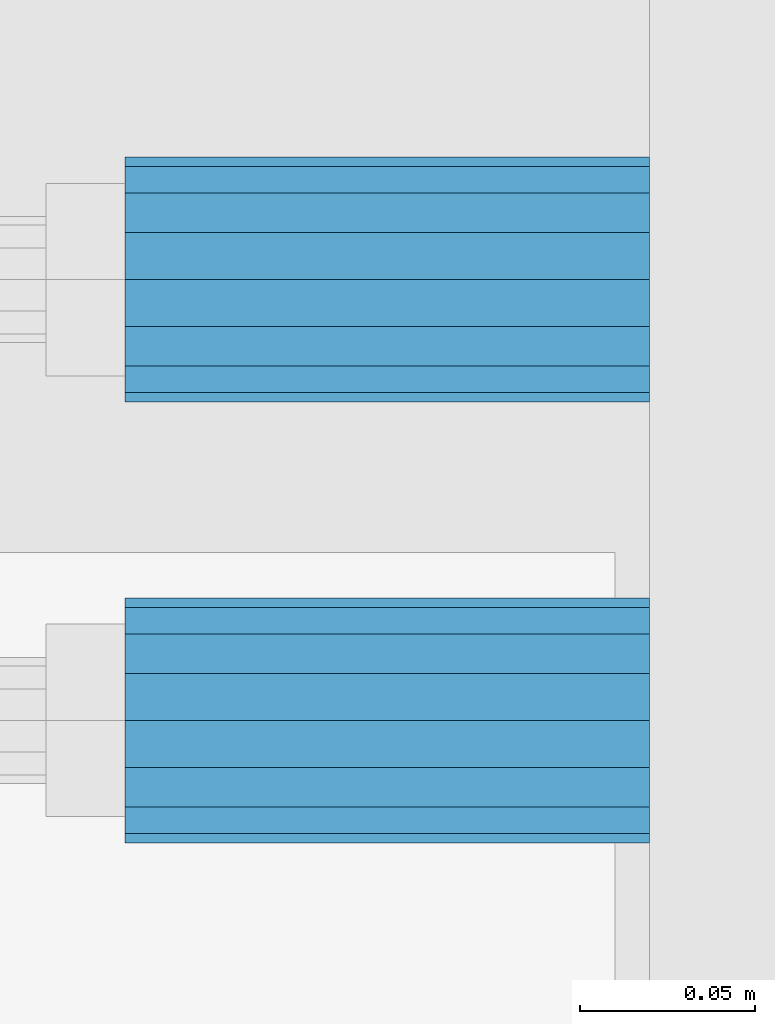
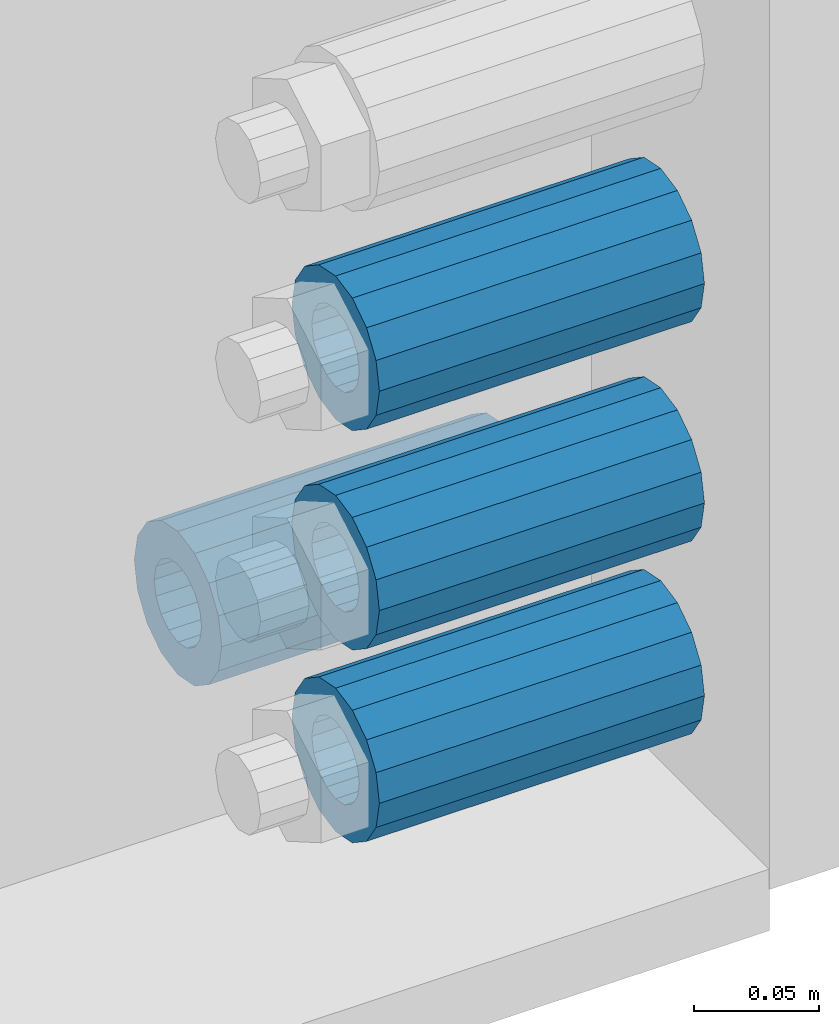
# One storey, part 168 of 240: 4 beams.
"""IFC2X3 building model written with IfcOpenShell, lengths in millimetres."""

import ifcopenshell
import ifcopenshell.guid

model = None  # the IFC model being written
_history = None  # IfcOwnerHistory: only IFC2X3 demands one
_inside = {}  # id of a spatial element -> (the spatial element, [elements in it])
_under = {}  # id of a project, library or spatial element -> (it, [spatial elements below it])
_declared = {}  # id of a project -> (the project, [libraries it declares])
_typed = {}  # id of a type object -> (the type object, [elements of that type])
_made_of = {}  # id of a material, layer set ... -> (it, [elements and type objects made of it])


def new_model(schema):
    """Start an empty IFC model of exactly this schema.

    Asked for "IFC4X3", IfcOpenShell would pick the latest addendum, in which some entities
    have other attributes; the version numbers below select the first issue.
    IFC2X3 requires an IfcOwnerHistory on every rooted entity: one is made here for all.
    """
    global model, _history
    if schema == "IFC4X3":
        model = ifcopenshell.file(schema_version=(4, 3, 0, 0))
    else:
        model = ifcopenshell.file(schema=schema)
    _inside.clear()
    _under.clear()
    _declared.clear()
    _typed.clear()
    _made_of.clear()
    _history = None
    if model.schema == "IFC2X3":
        org = make("IfcOrganization", Name="unknown")
        user = make(
            "IfcPersonAndOrganization",
            ThePerson=make("IfcPerson", FamilyName="unknown"),
            TheOrganization=org,
        )
        app = make(
            "IfcApplication",
            ApplicationDeveloper=org,
            Version="unknown",
            ApplicationFullName="unknown",
            ApplicationIdentifier="unknown",
        )
        _history = make(
            "IfcOwnerHistory",
            OwningUser=user,
            OwningApplication=app,
            ChangeAction="ADDED",
            CreationDate=0,
        )
    return model


def make(cls, **values):
    """One entity of the class cls with the attributes given. An attribute that is None is left unset."""
    return model.create_entity(
        cls, **{name: value for name, value in values.items() if value is not None}
    )


def rooted(cls, **values):
    """An entity with a GlobalId (a new one), such as an element, a storey or a relation."""
    return make(cls, GlobalId=ifcopenshell.guid.new(), OwnerHistory=_history, **values)


def si_unit(unit_type, name, prefix=None):
    """IfcSIUnit, for example si_unit("LENGTHUNIT", "METRE", prefix="MILLI")."""
    return make("IfcSIUnit", UnitType=unit_type, Prefix=prefix, Name=name)


def assignment(units):
    """IfcUnitAssignment: the units of a project."""
    return None if units is None else make("IfcUnitAssignment", Units=units)


def point(xyz):
    """IfcCartesianPoint."""
    return None if xyz is None else make("IfcCartesianPoint", Coordinates=xyz)


def direction(xyz):
    """IfcDirection."""
    return None if xyz is None else make("IfcDirection", DirectionRatios=xyz)


def frame(location, z_axis=None, x_axis=None):
    """IfcAxis2Placement3D, a coordinate frame: its origin and axes. An axis left out is left unset."""
    return make(
        "IfcAxis2Placement3D",
        Location=point(location),
        Axis=direction(z_axis),
        RefDirection=direction(x_axis),
    )


def origin_with_axes():
    """The frame at (0, 0, 0) with the z axis (0, 0, 1) and the x axis (1, 0, 0) written out."""
    return frame((0.0, 0.0, 0.0), z_axis=(0.0, 0.0, 1.0), x_axis=(1.0, 0.0, 0.0))


def place(relative_to, where):
    """IfcLocalPlacement: puts the frame where relative to a parent placement (None: the world)."""
    return make(
        "IfcLocalPlacement", PlacementRelTo=relative_to, RelativePlacement=where
    )


def context(
    kind, dimensions, precision=None, world=None, true_north=None, identifier=None
):
    """IfcGeometricRepresentationContext, for example the 3D "Model" context."""
    return make(
        "IfcGeometricRepresentationContext",
        ContextIdentifier=identifier,
        ContextType=kind,
        CoordinateSpaceDimension=dimensions,
        Precision=precision,
        WorldCoordinateSystem=world,
        TrueNorth=true_north,
    )


def subcontext(parent, identifier, kind, view, scale=None):
    """IfcGeometricRepresentationSubContext, for example "Body" below "Model"."""
    return make(
        "IfcGeometricRepresentationSubContext",
        ContextIdentifier=identifier,
        ContextType=kind,
        ParentContext=parent,
        TargetScale=scale,
        TargetView=view,
    )


def project(units=None, contexts=None):
    """IfcProject with its units and contexts."""
    return rooted(
        "IfcProject",
        Name="project",
        RepresentationContexts=contexts,
        UnitsInContext=assignment(units),
    )


def spatial(cls, under=None, at=None, **own):
    """A site, building, storey or space (cls), placed at a placement, below another one or the project."""
    s = rooted(cls, ObjectPlacement=at, **own)
    if under is not None:
        _under.setdefault(under.id(), (under, []))[1].append(s)
    return s


def faces_of(points, faces, orient=None, outer=None):
    """IfcFace entities. A face is a list of loops; a loop is a list of indices into points, from 0.

    orient and outer hold one flag for each loop. By default every Orientation is true, the
    first loop of a face is its IfcFaceOuterBound and the others are IfcFaceBound.
    """
    made = []
    for i, loops in enumerate(faces):
        bounds = []
        for j, loop in enumerate(loops):
            is_outer = j == 0 if outer is None else outer[i][j]
            bounds.append(
                make(
                    "IfcFaceOuterBound" if is_outer else "IfcFaceBound",
                    Bound=make("IfcPolyLoop", Polygon=[points[k] for k in loop]),
                    Orientation=True if orient is None else orient[i][j],
                )
            )
        made.append(make("IfcFace", Bounds=bounds))
    return made


def faceted_brep(points, faces, orient=None, outer=None, voids=None):
    """IfcFacetedBrep: a solid bounded by flat faces; with voids (closed shells), ...WithVoids."""
    shared = [point(p) for p in points]
    hull = make("IfcClosedShell", CfsFaces=faces_of(shared, faces, orient, outer))
    if voids is None:
        return make("IfcFacetedBrep", Outer=hull)
    return make(
        "IfcFacetedBrepWithVoids",
        Outer=hull,
        Voids=[
            make(cls, CfsFaces=faces_of(shared, fs, o, b)) for cls, fs, o, b in voids
        ],
    )


def shape(context_of_items, identifier, shape_type, items):
    """IfcShapeRepresentation: the items that make up one representation, for example the "Body"."""
    return make(
        "IfcShapeRepresentation",
        ContextOfItems=context_of_items,
        RepresentationIdentifier=identifier,
        RepresentationType=shape_type,
        Items=items,
    )


def material(Name=None, Category=None):
    """IfcMaterial."""
    return make("IfcMaterial", Name=Name, Category=Category)


def made_of(thing, what):
    """Note that an element or type object is made of a material, layer set ...; save() writes the relation."""
    if what is not None:
        _made_of.setdefault(what.id(), (what, []))[1].append(thing)
    return thing


def type_object(cls, material=None, **own):
    """A type object (cls), such as IfcWallType, which elements share."""
    return made_of(rooted(cls, **own), material)


def element(
    cls,
    number,
    at=None,
    inside=None,
    cuts=None,
    type_object=None,
    material=None,
    context=None,
    identifier="Body",
    shape_type=None,
    held_by="IfcProductDefinitionShape",
    body=None,
    shapes=None,
    **own,
):
    """One element of the class cls, such as IfcWall. Its Tag is "e" and its number.

    at: its placement. inside: the storey or other place that contains it. cuts: it is an
    opening in that element (IfcRelVoidsElement). A single representation is given by context,
    identifier, shape_type and body (its items); several are given by shapes. held_by: the class
    of the entity that holds the representations. save() writes the other relations.
    """
    e = rooted(cls, Tag="e%d" % number, ObjectPlacement=at, **own)
    if body is not None:
        shapes = [shape(context, identifier, shape_type, body)]
    if shapes is not None:
        e.Representation = make(held_by, Representations=shapes)
    if inside is not None:
        _inside.setdefault(inside.id(), (inside, []))[1].append(e)
    if cuts is not None:
        rooted(
            "IfcRelVoidsElement", RelatingBuildingElement=cuts, RelatedOpeningElement=e
        )
    if type_object is not None:
        _typed.setdefault(type_object.id(), (type_object, []))[1].append(e)
    return made_of(e, material)


def aggregate(whole, parts):
    """IfcRelAggregates: a whole, such as a stair, and the parts it consists of."""
    return rooted("IfcRelAggregates", RelatingObject=whole, RelatedObjects=parts)


def save(model, path):
    """Write the relations noted so far, then the file.

    IfcRelAggregates (storeys below a building ...), IfcRelContainedInSpatialStructure (elements
    in a storey), IfcRelDefinesByType, IfcRelAssociatesMaterial and IfcRelDeclares: one each for
    every whole, place, type object, material and project.
    """
    for whole, parts in _under.values():
        aggregate(whole, parts)
    for where, things in _inside.values():
        rooted(
            "IfcRelContainedInSpatialStructure",
            RelatedElements=things,
            RelatingStructure=where,
        )
    for kind, things in _typed.values():
        rooted("IfcRelDefinesByType", RelatedObjects=things, RelatingType=kind)
    for what, things in _made_of.values():
        rooted("IfcRelAssociatesMaterial", RelatedObjects=things, RelatingMaterial=what)
    for by, libraries in _declared.values():
        rooted("IfcRelDeclares", RelatingContext=by, RelatedDefinitions=libraries)
    model.write(path)


model = new_model("IFC2X3")

# Units and contexts
model_context = context("Model", 3, precision=1e-05, world=origin_with_axes())
body_context = subcontext(model_context, "Body", "Model", "MODEL_VIEW")
ifc_project = project(units=[si_unit("LENGTHUNIT", "METRE", prefix="MILLI"), si_unit("AREAUNIT", "SQUARE_METRE"), si_unit("VOLUMEUNIT", "CUBIC_METRE"), si_unit("MASSUNIT", "GRAM", prefix="KILO"), si_unit("TIMEUNIT", "SECOND"), si_unit("PLANEANGLEUNIT", "RADIAN"), si_unit("SOLIDANGLEUNIT", "STERADIAN"), si_unit("THERMODYNAMICTEMPERATUREUNIT", "DEGREE_CELSIUS"), si_unit("LUMINOUSINTENSITYUNIT", "LUMEN")], contexts=[model_context])

# Site, building, storey
site_placement = place(None, origin_with_axes())
site = spatial("IfcSite", under=ifc_project, at=site_placement, CompositionType="ELEMENT")
building_placement = place(site_placement, origin_with_axes())
building = spatial("IfcBuilding", under=site, at=building_placement, Name="Standard", CompositionType="ELEMENT")
storey_placement = place(building_placement, origin_with_axes())
storey = spatial("IfcBuildingStorey", under=building, at=storey_placement, Name="Undefined", CompositionType="ELEMENT", Elevation=0.0)

# Beams
ifc_material = material()
beam_type = type_object("IfcBeamType", PredefinedType="NOTDEFINED")
beam_1_placement = place(storey_placement, frame((56327.0, 35937.0, -606.0), z_axis=(0.0, 0.0, 1.0), x_axis=(1.0, 0.0, 0.0)))
element("IfcBeam", 1, at=beam_1_placement, inside=storey, type_object=beam_type, material=ifc_material, context=body_context, shape_type="Brep", body=[
    faceted_brep([(-1.31236447487026e-07, -18.9999999995492, -6.26459950581193e-09), (0.0, -17.5537111177146, 7.27098521493673), (150.0, -17.5537111177146, 7.27098521493673), (150.0, -19.0, 0.0), (0.0, -13.4350288425449, 13.4350288425444), (150.0, -13.4350288425449, 13.4350288425444), (0.0, -7.27098521493826, 17.5537111177144), (150.0, -7.27098521493826, 17.5537111177144), (-6.35918695479631e-09, 4.50199877377599e-10, 18.9999999937281), (150.0, 0.0, 19.0), (0.0, 7.27098521493826, 17.5537111177144), (150.0, 7.27098521493826, 17.5537111177144), (0.0, 13.4350288425449, 13.4350288425444), (150.0, 13.4350288425449, 13.4350288425444), (0.0, 17.5537111177146, 7.27098521493673), (150.0, 17.5537111177146, 7.27098521493673), (1.33248249767348e-07, 19.0000000004507, -6.26459950581193e-09), (150.0, 19.0, 0.0), (0.0, 17.5537111177146, -7.27098521493673), (150.0, 17.5537111177146, -7.27098521493673), (0.0, 13.4350288425449, -13.4350288425444), (150.0, 13.4350288425449, -13.4350288425444), (0.0, 7.27098521493826, -17.5537111177144), (150.0, 7.27098521493826, -17.5537111177144), (8.37098923511803e-09, 4.50313564215321e-10, -19.0000000062646), (150.0, 0.0, -19.0), (0.0, -7.27098521493826, -17.5537111177144), (150.0, -7.27098521493826, -17.5537111177144), (0.0, -13.4350288425449, -13.4350288425444), (150.0, -13.4350288425449, -13.4350288425444), (0.0, -17.5537111177146, -7.27098521493673), (150.0, -17.5537111177146, -7.27098521493673), (0.0, -35.0, 0.0), (7.27595761418343e-12, -32.335783637895, -13.3939201327739), (150.0, -32.3357836378964, -13.3939201327782), (150.0, -35.0, 0.0), (0.0, -24.7487373415292, -24.7487373415279), (150.0, -24.7487373415279, -24.7487373415292), (7.27595761418343e-12, -13.3939201327781, -32.3357836378891), (150.0, -13.3939201327776, -32.335783637895), (7.27595761418343e-12, 0.0, -35.0), (150.0, 0.0, -35.0), (7.27595761418343e-12, 13.3939201327782, -32.3357836378891), (150.0, 13.3939201327776, -32.335783637895), (0.0, 24.7487373415292, -24.7487373415279), (150.0, 24.7487373415279, -24.7487373415291), (7.27595761418343e-12, 32.335783637895, -13.3939201327739), (150.0, 32.3357836378964, -13.3939201327781), (0.0, 35.0, 0.0), (150.0, 35.0, 0.0), (0.0, 32.335783637895, 13.3939201327812), (150.0, 32.3357836378964, 13.3939201327781), (0.0, 24.7487373415292, 24.7487373415279), (150.0, 24.7487373415279, 24.7487373415292), (0.0, 13.3939201327781, 32.3357836378964), (150.0, 13.3939201327776, 32.335783637895), (0.0, 0.0, 35.0), (150.0, 0.0, 35.0), (0.0, -13.3939201327781, 32.3357836378964), (150.0, -13.3939201327776, 32.335783637895), (0.0, -24.7487373415292, 24.7487373415279), (150.0, -24.7487373415279, 24.7487373415292), (0.0, -32.335783637895, 13.3939201327812), (150.0, -32.3357836378964, 13.3939201327781)], [[[0, 1, 2, 3]], [[1, 4, 5, 2]], [[4, 6, 7, 5]], [[6, 8, 9, 7]], [[8, 10, 11, 9]], [[10, 12, 13, 11]], [[12, 14, 15, 13]], [[14, 16, 17, 15]], [[16, 18, 19, 17]], [[18, 20, 21, 19]], [[20, 22, 23, 21]], [[22, 24, 25, 23]], [[24, 26, 27, 25]], [[26, 28, 29, 27]], [[28, 30, 31, 29]], [[30, 0, 3, 31]], [[32, 33, 34, 35]], [[33, 36, 37, 34]], [[36, 38, 39, 37]], [[38, 40, 41, 39]], [[40, 42, 43, 41]], [[42, 44, 45, 43]], [[44, 46, 47, 45]], [[46, 48, 49, 47]], [[48, 50, 51, 49]], [[50, 52, 53, 51]], [[52, 54, 55, 53]], [[54, 56, 57, 55]], [[56, 58, 59, 57]], [[58, 60, 61, 59]], [[60, 62, 63, 61]], [[62, 32, 35, 63]], [[37, 39, 41, 43, 45, 47, 49, 51, 53, 55, 57, 59, 61, 63, 35, 34], [5, 7, 9, 11, 13, 15, 17, 19, 21, 23, 25, 27, 29, 31, 3, 2]], [[62, 60, 58, 56, 54, 52, 50, 48, 46, 44, 42, 40, 38, 36, 33, 32], [30, 28, 26, 24, 22, 20, 18, 16, 14, 12, 10, 8, 6, 4, 1, 0]]]),
])
beam_2_placement = place(storey_placement, frame((56327.0, 35937.0, -713.0), z_axis=(0.0, 0.0, 1.0), x_axis=(1.0, 0.0, 0.0)))
element("IfcBeam", 2, at=beam_2_placement, inside=storey, type_object=beam_type, material=ifc_material, context=body_context, shape_type="Brep", body=[
    faceted_brep([(-1.31236447487026e-07, -18.9999999995492, -6.26459950581193e-09), (0.0, -17.5537111177146, 7.27098521493673), (150.0, -17.5537111177146, 7.27098521493673), (150.0, -19.0, 0.0), (0.0, -13.4350288425449, 13.4350288425444), (150.0, -13.4350288425449, 13.4350288425444), (0.0, -7.27098521493826, 17.5537111177144), (150.0, -7.27098521493826, 17.5537111177144), (-6.35918695479631e-09, 4.50199877377599e-10, 18.9999999937281), (150.0, 0.0, 19.0), (0.0, 7.27098521493826, 17.5537111177144), (150.0, 7.27098521493826, 17.5537111177144), (0.0, 13.4350288425449, 13.4350288425444), (150.0, 13.4350288425449, 13.4350288425444), (0.0, 17.5537111177146, 7.27098521493673), (150.0, 17.5537111177146, 7.27098521493673), (1.33248249767348e-07, 19.0000000004507, -6.26459950581193e-09), (150.0, 19.0, 0.0), (0.0, 17.5537111177146, -7.27098521493673), (150.0, 17.5537111177146, -7.27098521493673), (0.0, 13.4350288425449, -13.4350288425444), (150.0, 13.4350288425449, -13.4350288425444), (0.0, 7.27098521493826, -17.5537111177144), (150.0, 7.27098521493826, -17.5537111177144), (8.37098923511803e-09, 4.50313564215321e-10, -19.0000000062646), (150.0, 0.0, -19.0), (0.0, -7.27098521493826, -17.5537111177144), (150.0, -7.27098521493826, -17.5537111177144), (0.0, -13.4350288425449, -13.4350288425444), (150.0, -13.4350288425449, -13.4350288425444), (0.0, -17.5537111177146, -7.27098521493673), (150.0, -17.5537111177146, -7.27098521493673), (0.0, -35.0, 0.0), (7.27595761418343e-12, -32.335783637895, -13.3939201327739), (150.0, -32.3357836378964, -13.3939201327782), (150.0, -35.0, 0.0), (0.0, -24.7487373415292, -24.7487373415279), (150.0, -24.7487373415279, -24.7487373415292), (7.27595761418343e-12, -13.3939201327781, -32.3357836378891), (150.0, -13.3939201327776, -32.335783637895), (7.27595761418343e-12, 0.0, -35.0), (150.0, 0.0, -35.0), (7.27595761418343e-12, 13.3939201327782, -32.3357836378891), (150.0, 13.3939201327776, -32.335783637895), (0.0, 24.7487373415292, -24.7487373415279), (150.0, 24.7487373415279, -24.7487373415291), (7.27595761418343e-12, 32.335783637895, -13.3939201327739), (150.0, 32.3357836378964, -13.3939201327781), (0.0, 35.0, 0.0), (150.0, 35.0, 0.0), (0.0, 32.335783637895, 13.3939201327812), (150.0, 32.3357836378964, 13.3939201327781), (0.0, 24.7487373415292, 24.7487373415279), (150.0, 24.7487373415279, 24.7487373415292), (0.0, 13.3939201327781, 32.3357836378964), (150.0, 13.3939201327776, 32.335783637895), (0.0, 0.0, 35.0), (150.0, 0.0, 35.0), (0.0, -13.3939201327781, 32.3357836378964), (150.0, -13.3939201327776, 32.335783637895), (0.0, -24.7487373415292, 24.7487373415279), (150.0, -24.7487373415279, 24.7487373415292), (0.0, -32.335783637895, 13.3939201327812), (150.0, -32.3357836378964, 13.3939201327781)], [[[0, 1, 2, 3]], [[1, 4, 5, 2]], [[4, 6, 7, 5]], [[6, 8, 9, 7]], [[8, 10, 11, 9]], [[10, 12, 13, 11]], [[12, 14, 15, 13]], [[14, 16, 17, 15]], [[16, 18, 19, 17]], [[18, 20, 21, 19]], [[20, 22, 23, 21]], [[22, 24, 25, 23]], [[24, 26, 27, 25]], [[26, 28, 29, 27]], [[28, 30, 31, 29]], [[30, 0, 3, 31]], [[32, 33, 34, 35]], [[33, 36, 37, 34]], [[36, 38, 39, 37]], [[38, 40, 41, 39]], [[40, 42, 43, 41]], [[42, 44, 45, 43]], [[44, 46, 47, 45]], [[46, 48, 49, 47]], [[48, 50, 51, 49]], [[50, 52, 53, 51]], [[52, 54, 55, 53]], [[54, 56, 57, 55]], [[56, 58, 59, 57]], [[58, 60, 61, 59]], [[60, 62, 63, 61]], [[62, 32, 35, 63]], [[37, 39, 41, 43, 45, 47, 49, 51, 53, 55, 57, 59, 61, 63, 35, 34], [5, 7, 9, 11, 13, 15, 17, 19, 21, 23, 25, 27, 29, 31, 3, 2]], [[62, 60, 58, 56, 54, 52, 50, 48, 46, 44, 42, 40, 38, 36, 33, 32], [30, 28, 26, 24, 22, 20, 18, 16, 14, 12, 10, 8, 6, 4, 1, 0]]]),
])
beam_3_placement = place(storey_placement, frame((56327.0, 36063.0, -807.0), z_axis=(0.0, 0.0, 1.0), x_axis=(1.0, 0.0, 0.0)))
element("IfcBeam", 3, at=beam_3_placement, inside=storey, type_object=beam_type, material=ifc_material, context=body_context, shape_type="Brep", body=[
    faceted_brep([(-1.31236447487026e-07, -18.9999999995492, -6.26459950581193e-09), (0.0, -17.5537111177146, 7.27098521493673), (150.0, -17.5537111177146, 7.27098521493673), (150.0, -19.0, 0.0), (0.0, -13.4350288425449, 13.4350288425444), (150.0, -13.4350288425449, 13.4350288425444), (0.0, -7.27098521493826, 17.5537111177144), (150.0, -7.27098521493826, 17.5537111177144), (-6.35918695479631e-09, 4.50199877377599e-10, 18.9999999937281), (150.0, 0.0, 19.0), (0.0, 7.27098521493826, 17.5537111177144), (150.0, 7.27098521493826, 17.5537111177144), (0.0, 13.4350288425449, 13.4350288425444), (150.0, 13.4350288425449, 13.4350288425444), (0.0, 17.5537111177146, 7.27098521493673), (150.0, 17.5537111177146, 7.27098521493673), (1.33248249767348e-07, 19.0000000004507, -6.26459950581193e-09), (150.0, 19.0, 0.0), (0.0, 17.5537111177146, -7.27098521493673), (150.0, 17.5537111177146, -7.27098521493673), (0.0, 13.4350288425449, -13.4350288425444), (150.0, 13.4350288425449, -13.4350288425444), (0.0, 7.27098521493826, -17.5537111177144), (150.0, 7.27098521493826, -17.5537111177144), (8.37098923511803e-09, 4.50313564215321e-10, -19.0000000062646), (150.0, 0.0, -19.0), (0.0, -7.27098521493826, -17.5537111177144), (150.0, -7.27098521493826, -17.5537111177144), (0.0, -13.4350288425449, -13.4350288425444), (150.0, -13.4350288425449, -13.4350288425444), (0.0, -17.5537111177146, -7.27098521493673), (150.0, -17.5537111177146, -7.27098521493673), (0.0, -35.0, 0.0), (7.27595761418343e-12, -32.335783637895, -13.3939201327739), (150.0, -32.3357836378964, -13.3939201327782), (150.0, -35.0, 0.0), (0.0, -24.7487373415292, -24.7487373415279), (150.0, -24.7487373415279, -24.7487373415292), (7.27595761418343e-12, -13.3939201327781, -32.3357836378891), (150.0, -13.3939201327776, -32.335783637895), (7.27595761418343e-12, 0.0, -35.0), (150.0, 0.0, -35.0), (7.27595761418343e-12, 13.3939201327782, -32.3357836378891), (150.0, 13.3939201327776, -32.335783637895), (0.0, 24.7487373415292, -24.7487373415279), (150.0, 24.7487373415279, -24.7487373415291), (7.27595761418343e-12, 32.335783637895, -13.3939201327739), (150.0, 32.3357836378964, -13.3939201327781), (0.0, 35.0, 0.0), (150.0, 35.0, 0.0), (0.0, 32.335783637895, 13.3939201327812), (150.0, 32.3357836378964, 13.3939201327781), (0.0, 24.7487373415292, 24.7487373415279), (150.0, 24.7487373415279, 24.7487373415292), (0.0, 13.3939201327781, 32.3357836378964), (150.0, 13.3939201327776, 32.335783637895), (0.0, 0.0, 35.0), (150.0, 0.0, 35.0), (0.0, -13.3939201327781, 32.3357836378964), (150.0, -13.3939201327776, 32.335783637895), (0.0, -24.7487373415292, 24.7487373415279), (150.0, -24.7487373415279, 24.7487373415292), (0.0, -32.335783637895, 13.3939201327812), (150.0, -32.3357836378964, 13.3939201327781)], [[[0, 1, 2, 3]], [[1, 4, 5, 2]], [[4, 6, 7, 5]], [[6, 8, 9, 7]], [[8, 10, 11, 9]], [[10, 12, 13, 11]], [[12, 14, 15, 13]], [[14, 16, 17, 15]], [[16, 18, 19, 17]], [[18, 20, 21, 19]], [[20, 22, 23, 21]], [[22, 24, 25, 23]], [[24, 26, 27, 25]], [[26, 28, 29, 27]], [[28, 30, 31, 29]], [[30, 0, 3, 31]], [[32, 33, 34, 35]], [[33, 36, 37, 34]], [[36, 38, 39, 37]], [[38, 40, 41, 39]], [[40, 42, 43, 41]], [[42, 44, 45, 43]], [[44, 46, 47, 45]], [[46, 48, 49, 47]], [[48, 50, 51, 49]], [[50, 52, 53, 51]], [[52, 54, 55, 53]], [[54, 56, 57, 55]], [[56, 58, 59, 57]], [[58, 60, 61, 59]], [[60, 62, 63, 61]], [[62, 32, 35, 63]], [[37, 39, 41, 43, 45, 47, 49, 51, 53, 55, 57, 59, 61, 63, 35, 34], [5, 7, 9, 11, 13, 15, 17, 19, 21, 23, 25, 27, 29, 31, 3, 2]], [[62, 60, 58, 56, 54, 52, 50, 48, 46, 44, 42, 40, 38, 36, 33, 32], [30, 28, 26, 24, 22, 20, 18, 16, 14, 12, 10, 8, 6, 4, 1, 0]]]),
])
beam_4_placement = place(storey_placement, frame((56327.0, 35937.0, -807.0), z_axis=(0.0, 0.0, 1.0), x_axis=(1.0, 0.0, 0.0)))
element("IfcBeam", 4, at=beam_4_placement, inside=storey, type_object=beam_type, material=ifc_material, context=body_context, shape_type="Brep", body=[
    faceted_brep([(-1.31236447487026e-07, -18.9999999995492, -6.26459950581193e-09), (0.0, -17.5537111177146, 7.27098521493673), (150.0, -17.5537111177146, 7.27098521493673), (150.0, -19.0, 0.0), (0.0, -13.4350288425449, 13.4350288425444), (150.0, -13.4350288425449, 13.4350288425444), (0.0, -7.27098521493826, 17.5537111177144), (150.0, -7.27098521493826, 17.5537111177144), (-6.35918695479631e-09, 4.50199877377599e-10, 18.9999999937281), (150.0, 0.0, 19.0), (0.0, 7.27098521493826, 17.5537111177144), (150.0, 7.27098521493826, 17.5537111177144), (0.0, 13.4350288425449, 13.4350288425444), (150.0, 13.4350288425449, 13.4350288425444), (0.0, 17.5537111177146, 7.27098521493673), (150.0, 17.5537111177146, 7.27098521493673), (1.33248249767348e-07, 19.0000000004507, -6.26459950581193e-09), (150.0, 19.0, 0.0), (0.0, 17.5537111177146, -7.27098521493673), (150.0, 17.5537111177146, -7.27098521493673), (0.0, 13.4350288425449, -13.4350288425444), (150.0, 13.4350288425449, -13.4350288425444), (0.0, 7.27098521493826, -17.5537111177144), (150.0, 7.27098521493826, -17.5537111177144), (8.37098923511803e-09, 4.50313564215321e-10, -19.0000000062646), (150.0, 0.0, -19.0), (0.0, -7.27098521493826, -17.5537111177144), (150.0, -7.27098521493826, -17.5537111177144), (0.0, -13.4350288425449, -13.4350288425444), (150.0, -13.4350288425449, -13.4350288425444), (0.0, -17.5537111177146, -7.27098521493673), (150.0, -17.5537111177146, -7.27098521493673), (0.0, -35.0, 0.0), (7.27595761418343e-12, -32.335783637895, -13.3939201327739), (150.0, -32.3357836378964, -13.3939201327782), (150.0, -35.0, 0.0), (0.0, -24.7487373415292, -24.7487373415279), (150.0, -24.7487373415279, -24.7487373415292), (7.27595761418343e-12, -13.3939201327781, -32.3357836378891), (150.0, -13.3939201327776, -32.335783637895), (7.27595761418343e-12, 0.0, -35.0), (150.0, 0.0, -35.0), (7.27595761418343e-12, 13.3939201327782, -32.3357836378891), (150.0, 13.3939201327776, -32.335783637895), (0.0, 24.7487373415292, -24.7487373415279), (150.0, 24.7487373415279, -24.7487373415291), (7.27595761418343e-12, 32.335783637895, -13.3939201327739), (150.0, 32.3357836378964, -13.3939201327781), (0.0, 35.0, 0.0), (150.0, 35.0, 0.0), (0.0, 32.335783637895, 13.3939201327812), (150.0, 32.3357836378964, 13.3939201327781), (0.0, 24.7487373415292, 24.7487373415279), (150.0, 24.7487373415279, 24.7487373415292), (0.0, 13.3939201327781, 32.3357836378964), (150.0, 13.3939201327776, 32.335783637895), (0.0, 0.0, 35.0), (150.0, 0.0, 35.0), (0.0, -13.3939201327781, 32.3357836378964), (150.0, -13.3939201327776, 32.335783637895), (0.0, -24.7487373415292, 24.7487373415279), (150.0, -24.7487373415279, 24.7487373415292), (0.0, -32.335783637895, 13.3939201327812), (150.0, -32.3357836378964, 13.3939201327781)], [[[0, 1, 2, 3]], [[1, 4, 5, 2]], [[4, 6, 7, 5]], [[6, 8, 9, 7]], [[8, 10, 11, 9]], [[10, 12, 13, 11]], [[12, 14, 15, 13]], [[14, 16, 17, 15]], [[16, 18, 19, 17]], [[18, 20, 21, 19]], [[20, 22, 23, 21]], [[22, 24, 25, 23]], [[24, 26, 27, 25]], [[26, 28, 29, 27]], [[28, 30, 31, 29]], [[30, 0, 3, 31]], [[32, 33, 34, 35]], [[33, 36, 37, 34]], [[36, 38, 39, 37]], [[38, 40, 41, 39]], [[40, 42, 43, 41]], [[42, 44, 45, 43]], [[44, 46, 47, 45]], [[46, 48, 49, 47]], [[48, 50, 51, 49]], [[50, 52, 53, 51]], [[52, 54, 55, 53]], [[54, 56, 57, 55]], [[56, 58, 59, 57]], [[58, 60, 61, 59]], [[60, 62, 63, 61]], [[62, 32, 35, 63]], [[37, 39, 41, 43, 45, 47, 49, 51, 53, 55, 57, 59, 61, 63, 35, 34], [5, 7, 9, 11, 13, 15, 17, 19, 21, 23, 25, 27, 29, 31, 3, 2]], [[62, 60, 58, 56, 54, 52, 50, 48, 46, 44, 42, 40, 38, 36, 33, 32], [30, 28, 26, 24, 22, 20, 18, 16, 14, 12, 10, 8, 6, 4, 1, 0]]]),
])

save(model, "model.ifc")
